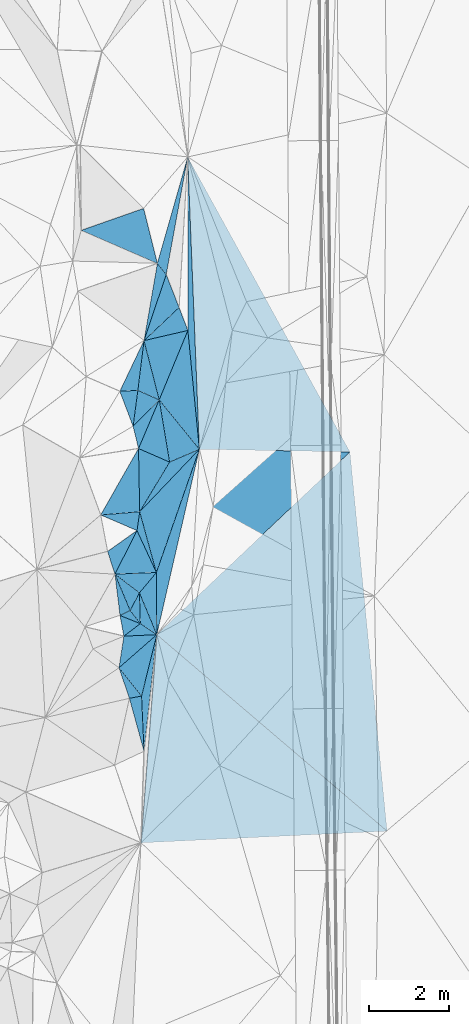
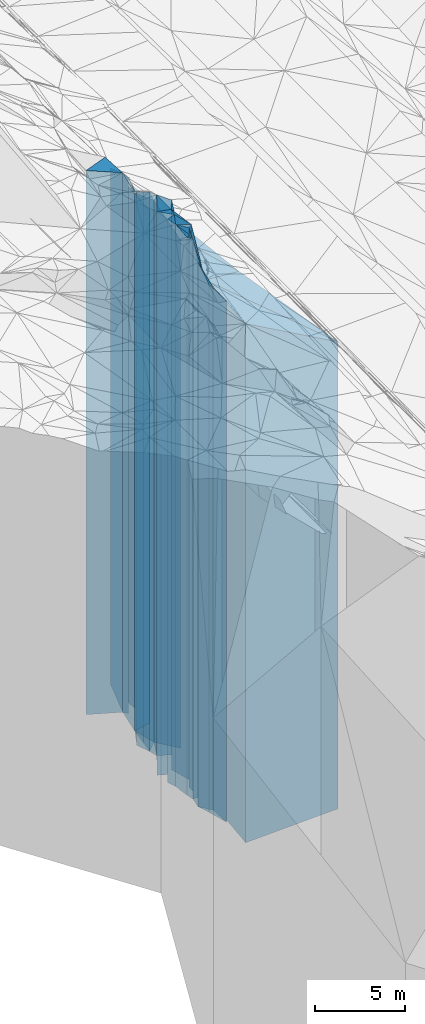
# One storey, part 200 of 275: 42 plates.
"""IFC2X3 building model written with IfcOpenShell, lengths in millimetres."""

from ifc_helpers import new_model, si_unit, frame, origin_with_axes, place, context, subcontext, project, spatial, faceted_brep, material, type_object, element, save


model = new_model("IFC2X3")

# Units and contexts
model_context = context("Model", 3, precision=1e-05, world=origin_with_axes())
body_context = subcontext(model_context, "Body", "Model", "MODEL_VIEW")
ifc_project = project(units=[si_unit("LENGTHUNIT", "METRE", prefix="MILLI"), si_unit("AREAUNIT", "SQUARE_METRE"), si_unit("VOLUMEUNIT", "CUBIC_METRE"), si_unit("MASSUNIT", "GRAM", prefix="KILO"), si_unit("TIMEUNIT", "SECOND"), si_unit("PLANEANGLEUNIT", "RADIAN"), si_unit("SOLIDANGLEUNIT", "STERADIAN"), si_unit("THERMODYNAMICTEMPERATUREUNIT", "DEGREE_CELSIUS"), si_unit("LUMINOUSINTENSITYUNIT", "LUMEN")], contexts=[model_context])

# Site, building, storey
site_placement = place(None, origin_with_axes())
site = spatial("IfcSite", under=ifc_project, at=site_placement, CompositionType="ELEMENT")
building_placement = place(site_placement, origin_with_axes())
building = spatial("IfcBuilding", under=site, at=building_placement, Name="Undefined", CompositionType="ELEMENT")
storey_placement = place(building_placement, origin_with_axes())
storey = spatial("IfcBuildingStorey", under=building, at=storey_placement, Name="Undefined", CompositionType="ELEMENT", Elevation=0.0)

# Plates
ifc_material = material()
plate_type_1 = type_object("IfcPlateType", PredefinedType="NOTDEFINED")
plate_1_placement = place(storey_placement, frame((-97470.1992591379, 36582.1176722173, 23411.5), z_axis=(0.999205181096027, 0.0398623390038303, 0.0), x_axis=(0.0398623390038315, -0.999205181096027, 0.0)))
element("IfcPlate", 1, at=plate_1_placement, inside=storey, type_object=plate_type_1, material=ifc_material, Name="00", context=body_context, shape_type="Brep", body=[
    faceted_brep([(0.0, -19574.5109863281, 0.0), (7486.21093749999, -15583.5, 3739.80737304688), (7486.21093749999, 15583.5, 3739.80737304688), (0.0, 15583.5, 0.0), (7271.146484375, -19012.5109863281, -8.73114913702011e-09), (7271.146484375, 15583.5, -8.73114913702011e-09)], [[[0, 1, 2, 3]], [[1, 4, 5, 2]], [[4, 0, 3, 5]], [[5, 3, 2]], [[4, 1, 0]]]),
])
plate_type_2 = type_object("IfcPlateType", PredefinedType="NOTDEFINED")
plate_2_placement = place(storey_placement, frame((-98238.1983915718, 24706.1417825239, 23411.5), z_axis=(0.649050026928947, 0.760745727916715, 0.0), x_axis=(0.760745727916717, -0.649050026928945, 0.0)))
element("IfcPlate", 2, at=plate_2_placement, inside=storey, type_object=plate_type_2, material=ifc_material, Name="00", context=body_context, shape_type="Brep", body=[
    faceted_brep([(0.0, -19434.5109863281, 0.0), (704.255493164048, -15583.5, 6574.982421875), (704.255493164048, 15583.5, 6574.982421875), (0.0, 15583.5, 0.0), (7528.404296875, -16175.5109863281, -2.89292074739933e-08), (7528.404296875, 15583.5, -2.89292074739933e-08)], [[[0, 1, 2, 3]], [[1, 4, 5, 2]], [[4, 0, 3, 5]], [[5, 3, 2]], [[4, 1, 0]]]),
])
plate_type_3 = type_object("IfcPlateType", PredefinedType="NOTDEFINED")
plate_3_placement = place(storey_placement, frame((-98238.1983915718, 24706.1417825239, 23707.5), z_axis=(0.997106036471852, -0.076023365035977, 0.0), x_axis=(-0.0760233650359758, -0.997106036471852, 0.0)))
element("IfcPlate", 3, at=plate_3_placement, inside=storey, type_object=plate_type_3, material=ifc_material, Name="00", context=body_context, shape_type="Brep", body=[
    faceted_brep([(3.63797880709171e-12, -19138.5, 0.0), (4436.76904296874, -15879.5, 6082.1005859375), (4436.76904296874, 15879.5, 6082.1005859375), (3.63797880709171e-12, 15879.5, 0.0), (5192.95703125, -19442.5, 8.73114913702011e-09), (5192.95703125, 15879.5, 8.73114913702011e-09)], [[[0, 1, 2, 3]], [[1, 4, 5, 2]], [[4, 0, 3, 5]], [[5, 3, 2]], [[4, 1, 0]]]),
])
plate_type_4 = type_object("IfcPlateType", PredefinedType="NOTDEFINED")
plate_4_placement = place(storey_placement, frame((-98648.2817788003, 24980.7626402883, 25337.0), z_axis=(0.606668938331786, -0.794954589434757, 0.0), x_axis=(-0.794954589434757, -0.606668938331787, 0.0)))
element("IfcPlate", 4, at=plate_4_placement, inside=storey, type_object=plate_type_4, material=ifc_material, Name="00", context=body_context, shape_type="Brep", body=[
    faceted_brep([(-7.27595761418343e-12, -19333.0, -1.45519152283669e-11), (-159.393722534194, -17509.0, 467.095977783189), (-159.393722534194, 17509.0, 467.095977783189), (-7.27595761418343e-12, 17509.0, -1.45519152283669e-11), (514.198425292969, -20573.0, -8.14907252788544e-10), (514.198425292969, 17509.0, -8.14907252788544e-10)], [[[0, 1, 2, 3]], [[1, 4, 5, 2]], [[4, 0, 3, 5]], [[5, 3, 2]], [[4, 1, 0]]]),
])
plate_type_5 = type_object("IfcPlateType", PredefinedType="NOTDEFINED")
plate_5_placement = place(storey_placement, frame((-98670.1738100079, 25747.3921068297, 26249.0), z_axis=(0.885665246512403, -0.464324316744369, 0.0), x_axis=(-0.464324316744365, -0.885665246512405, 0.0)))
element("IfcPlate", 5, at=plate_5_placement, inside=storey, type_object=plate_type_5, material=ifc_material, Name="00", context=body_context, shape_type="Brep", body=[
    faceted_brep([(0.0, -19661.0, 1.45519152283669e-11), (668.812072753906, -18421.0, 375.353729248047), (668.812072753906, 18421.0, 375.353729248047), (0.0, 18421.0, 1.45519152283669e-11), (498.196746826179, -19541.0, -5.67524693906307e-10), (498.196746826179, 18421.0, -5.67524693906307e-10)], [[[0, 1, 2, 3]], [[1, 4, 5, 2]], [[4, 0, 3, 5]], [[5, 3, 2]], [[4, 1, 0]]]),
])
plate_type_6 = type_object("IfcPlateType", PredefinedType="NOTDEFINED")
plate_6_placement = place(storey_placement, frame((-98648.2817788003, 24980.7626402883, 26249.0), z_axis=(-0.789196179336092, -0.614141181261536, 0.0), x_axis=(-0.614141181261532, 0.789196179336096, 0.0)))
element("IfcPlate", 6, at=plate_6_placement, inside=storey, type_object=plate_type_6, material=ifc_material, Name="00", context=body_context, shape_type="Brep", body=[
    faceted_brep([(2.91038304567337e-11, -18421.0, 1.45519152283669e-11), (470.519104003935, -19541.0, 274.065246582039), (470.519104003935, 18421.0, 274.065246582039), (0.0, 18421.0, 1.45519152283669e-11), (412.310577392607, -19541.0, 5.67524693906307e-10), (412.310577392607, 18421.0, 5.67524693906307e-10)], [[[0, 1, 2, 3]], [[1, 4, 5, 2]], [[4, 0, 3, 5]], [[5, 3, 2]], [[4, 1, 0]]]),
])
plate_type_7 = type_object("IfcPlateType", PredefinedType="NOTDEFINED")
plate_7_placement = place(storey_placement, frame((-99153.538195565, 25183.779765965, 26809.0), z_axis=(-0.436781510934569, 0.899567624865255, 0.0), x_axis=(0.899567624865254, 0.436781510934571, 0.0)))
element("IfcPlate", 7, at=plate_7_placement, inside=storey, type_object=plate_type_7, material=ifc_material, Name="00", context=body_context, shape_type="Brep", body=[
    faceted_brep([(0.0, -18981.0, 0.0), (335.143463134751, -19271.0, 978.661743164063), (335.143463134751, 18981.0, 978.661743164063), (0.0, 18981.0, 0.0), (280.178527832017, -18981.0, -2.00816430151463e-09), (280.178527832017, 18981.0, -2.00816430151463e-09)], [[[0, 1, 2, 3]], [[1, 4, 5, 2]], [[4, 0, 3, 5]], [[5, 3, 2]], [[4, 1, 0]]]),
])
plate_type_8 = type_object("IfcPlateType", PredefinedType="NOTDEFINED")
plate_8_placement = place(storey_placement, frame((-99057.0461609876, 24668.8144396924, 25337.0), z_axis=(0.988124865303162, -0.153653020047142, 0.0), x_axis=(-0.153653020047141, -0.988124865303162, 0.0)))
element("IfcPlate", 8, at=plate_8_placement, inside=storey, type_object=plate_type_8, material=ifc_material, Name="00", context=body_context, shape_type="Brep", body=[
    faceted_brep([(0.0, -20573.0, -1.45519152283669e-11), (-162.702514648436, -17509.0, 803.388366699219), (-162.702514648436, 17509.0, 803.388366699219), (-7.27595761418343e-12, 17509.0, -1.45519152283669e-11), (796.115539550783, -19533.0, 5.0931703299284e-10), (796.115539550783, 17509.0, 5.0931703299284e-10)], [[[0, 1, 2, 3]], [[1, 4, 5, 2]], [[4, 0, 3, 5]], [[5, 3, 2]], [[4, 1, 0]]]),
])
plate_type_9 = type_object("IfcPlateType", PredefinedType="NOTDEFINED")
plate_9_placement = place(storey_placement, frame((-99179.3717224447, 23882.1528497986, 25619.0), z_axis=(0.946352695047988, 0.323135539016386, 0.0), x_axis=(0.323135539016389, -0.946352695047987, 0.0)))
element("IfcPlate", 9, at=plate_9_placement, inside=storey, type_object=plate_type_9, material=ifc_material, Name="00", context=body_context, shape_type="Brep", body=[
    faceted_brep([(0.0, -19251.0, 1.45519152283669e-11), (846.64013671875, -17791.0, 304.959808349609), (846.64013671875, 17791.0, 304.959808349609), (0.0, 17791.0, 1.45519152283669e-11), (803.056640625, -18111.0, 0.0), (803.056640625, 17791.0, 0.0)], [[[0, 1, 2, 3]], [[1, 4, 5, 2]], [[4, 0, 3, 5]], [[5, 3, 2]], [[4, 1, 0]]]),
])
plate_type_10 = type_object("IfcPlateType", PredefinedType="NOTDEFINED")
plate_10_placement = place(storey_placement, frame((-98617.1926753688, 23179.4760257686, 25549.0), z_axis=(0.185997213942061, -0.982550271693918, 0.0), x_axis=(-0.982550271693919, -0.185997213942052, 0.0)))
element("IfcPlate", 10, at=plate_10_placement, inside=storey, type_object=plate_type_10, material=ifc_material, Name="00", context=body_context, shape_type="Brep", body=[
    faceted_brep([(1.45519152283669e-11, -17861.0, 0.0), (196.066696167021, -17721.0, 1360.13159179688), (196.066696167021, 17721.0, 1360.13159179688), (1.45519152283669e-11, 17721.0, 0.0), (308.058441162109, -18181.0, 1.65891833603382e-09), (308.058441162109, 17721.0, 1.65891833603382e-09)], [[[0, 1, 2, 3]], [[1, 4, 5, 2]], [[4, 0, 3, 5]], [[5, 3, 2]], [[4, 1, 0]]]),
])
plate_type_11 = type_object("IfcPlateType", PredefinedType="NOTDEFINED")
plate_11_placement = place(storey_placement, frame((-98617.1926753688, 23179.4760257686, 25337.0), z_axis=(0.999035664107292, 0.0439060570047157, 0.0), x_axis=(0.0439060570047185, -0.999035664107292, 0.0)))
element("IfcPlate", 11, at=plate_11_placement, inside=storey, type_object=plate_type_11, material=ifc_material, Name="00", context=body_context, shape_type="Brep", body=[
    faceted_brep([(0.0, -18073.0, 0.0), (-1508.55334472657, -17509.0, 445.658691406235), (-1508.55334472657, 17509.0, 445.658691406235), (-7.27595761418343e-12, 17509.0, -1.45519152283669e-11), (1374.19067382813, -17933.0, -1.04773789644241e-09), (1374.19067382813, 17509.0, -1.04773789644241e-09)], [[[0, 1, 2, 3]], [[1, 4, 5, 2]], [[4, 0, 3, 5]], [[5, 3, 2]], [[4, 1, 0]]]),
])
plate_type_12 = type_object("IfcPlateType", PredefinedType="NOTDEFINED")
plate_12_placement = place(storey_placement, frame((-99153.538195565, 25183.779765965, 26249.0), z_axis=(0.982894293571423, 0.184170593919695, 0.0), x_axis=(0.184170593919694, -0.982894293571423, 0.0)))
element("IfcPlate", 12, at=plate_12_placement, inside=storey, type_object=plate_type_12, material=ifc_material, Name="00", context=body_context, shape_type="Brep", body=[
    faceted_brep([(-7.27595761418343e-12, -19541.0, 0.0), (292.597747802727, -18421.0, 459.22387695311), (292.597747802727, 18421.0, 459.22387695311), (0.0, 18421.0, 1.45519152283669e-11), (523.927490234368, -19661.0, 1.45519152283669e-10), (523.927490234368, 18421.0, 1.45519152283669e-10)], [[[0, 1, 2, 3]], [[1, 4, 5, 2]], [[4, 0, 3, 5]], [[5, 3, 2]], [[4, 1, 0]]]),
])
plate_type_13 = type_object("IfcPlateType", PredefinedType="NOTDEFINED")
plate_13_placement = place(storey_placement, frame((-98617.1926753688, 23179.4760257686, 25337.0), z_axis=(-0.970540890617657, 0.240936463905083, 0.0), x_axis=(0.240936463905086, 0.970540890617656, 0.0)))
element("IfcPlate", 13, at=plate_13_placement, inside=storey, type_object=plate_type_13, material=ifc_material, Name="00", context=body_context, shape_type="Brep", body=[
    faceted_brep([(0.0, -18073.0, 0.0), (546.527160644531, -19533.0, 714.918212890625), (546.527160644531, 17509.0, 714.918212890625), (-7.27595761418343e-12, 17509.0, -1.45519152283669e-11), (1573.00512695313, -17509.0, -1.17870513349772e-09), (1573.00512695313, 17509.0, -1.17870513349772e-09)], [[[0, 1, 2, 3]], [[1, 4, 5, 2]], [[4, 0, 3, 5]], [[5, 3, 2]], [[4, 1, 0]]]),
])
plate_type_14 = type_object("IfcPlateType", PredefinedType="NOTDEFINED")
plate_14_placement = place(storey_placement, frame((-98566.6692560539, 35305.6810126596, 26179.0), z_axis=(0.330860922101641, -0.94367952728988, 0.0), x_axis=(-0.943679527289882, -0.330860922101635, 0.0)))
element("IfcPlate", 14, at=plate_14_placement, inside=storey, type_object=plate_type_14, material=ifc_material, Name="00", context=body_context, shape_type="Brep", body=[
    faceted_brep([(0.0, -18711.0, -1.45519152283669e-11), (129.411132812515, -18351.0, 1404.61840820311), (129.411132812515, 18351.0, 1404.61840820311), (0.0, 18351.0, -1.45519152283669e-11), (1645.14440917969, -18671.0, 7.15954229235649e-09), (1645.14440917969, 18351.0, 7.15954229235649e-09)], [[[0, 1, 2, 3]], [[1, 4, 5, 2]], [[4, 0, 3, 5]], [[5, 3, 2]], [[4, 1, 0]]]),
])
plate_type_15 = type_object("IfcPlateType", PredefinedType="NOTDEFINED")
plate_15_placement = place(storey_placement, frame((-98556.6871840692, 32018.9804850425, 26044.0), z_axis=(-0.947902138619609, 0.318561666872164, 0.0), x_axis=(0.318561666872161, 0.94790213861961, 0.0)))
element("IfcPlate", 15, at=plate_15_placement, inside=storey, type_object=plate_type_15, material=ifc_material, Name="00", context=body_context, shape_type="Brep", body=[
    faceted_brep([(1.45519152283669e-11, -18396.0, -1.45519152283669e-11), (1924.39343261719, -18486.0, 295.820983886719), (1924.39343261719, 18216.0, 295.820983886719), (2.91038304567337e-11, 18216.0, -2.91038304567337e-11), (1734.15686035156, -18216.0, 5.80621417611837e-09), (1734.15686035156, 18216.0, 5.80621417611837e-09)], [[[0, 1, 2, 3]], [[1, 4, 5, 2]], [[4, 0, 3, 5]], [[5, 3, 2]], [[4, 1, 0]]]),
])
plate_type_16 = type_object("IfcPlateType", PredefinedType="NOTDEFINED")
plate_16_placement = place(storey_placement, frame((-98224.058566093, 33937.3543283022, 25407.0), z_axis=(0.780651010687268, 0.62496719874962, 0.0), x_axis=(0.624967198749629, -0.780651010687261, 0.0)))
element("IfcPlate", 16, at=plate_16_placement, inside=storey, type_object=plate_type_16, material=ifc_material, Name="00", context=body_context, shape_type="Brep", body=[
    faceted_brep([(-1.45519152283669e-11, -19123.0, 0.0), (-1593.49987792969, -17579.0, 2241.39135742188), (-1593.49987792969, 17579.0, 2241.39135742188), (1.45519152283669e-11, 17579.0, 0.0), (351.710113525376, -18853.0, -4.65661287307739e-10), (351.710113525376, 17579.0, -4.65661287307739e-10)], [[[0, 1, 2, 3]], [[1, 4, 5, 2]], [[4, 0, 3, 5]], [[5, 3, 2]], [[4, 1, 0]]]),
])
plate_type_17 = type_object("IfcPlateType", PredefinedType="NOTDEFINED")
plate_17_placement = place(storey_placement, frame((-98556.6871840692, 32018.9804850425, 25349.0), z_axis=(-0.686407018989633, 0.72721757698901, 0.0), x_axis=(0.727217576989016, 0.686407018989626, 0.0)))
element("IfcPlate", 17, at=plate_17_placement, inside=storey, type_object=plate_type_17, material=ifc_material, Name="00", context=body_context, shape_type="Brep", body=[
    faceted_brep([(-1.45519152283669e-11, -19091.0, 0.0), (1530.064453125, -18911.0, 816.212341308594), (1530.064453125, 17521.0, 816.212341308594), (0.0, 17521.0, 1.45519152283669e-11), (1198.70764160155, -17521.0, 5.95173332840204e-09), (1198.70764160155, 17521.0, 5.95173332840204e-09)], [[[0, 1, 2, 3]], [[1, 4, 5, 2]], [[4, 0, 3, 5]], [[5, 3, 2]], [[4, 1, 0]]]),
])
plate_type_18 = type_object("IfcPlateType", PredefinedType="NOTDEFINED")
plate_18_placement = place(storey_placement, frame((-98556.6871840692, 32018.9804850425, 25274.0), z_axis=(-0.22571742799448, 0.974192815976158, 0.0), x_axis=(0.974192815976159, 0.225717427994477, 0.0)))
element("IfcPlate", 18, at=plate_18_placement, inside=storey, type_object=plate_type_18, material=ifc_material, Name="00", context=body_context, shape_type="Brep", body=[
    faceted_brep([(0.0, -19166.0, -1.81898940354586e-12), (1034.94519042967, -17596.0, 604.804443359382), (1034.94519042967, 17446.0, 604.804443359382), (-1.45519152283669e-11, 17446.0, 7.27595761418343e-12), (1119.86608886719, -17446.0, -2.46654963120818e-09), (1119.86608886719, 17446.0, -2.46654963120818e-09)], [[[0, 1, 2, 3]], [[1, 4, 5, 2]], [[4, 0, 3, 5]], [[5, 3, 2]], [[4, 1, 0]]]),
])
plate_type_19 = type_object("IfcPlateType", PredefinedType="NOTDEFINED")
plate_19_placement = place(storey_placement, frame((-98178.7387428365, 30546.0056122867, 25126.0), z_axis=(0.776233136003161, 0.630445968002571, 0.0), x_axis=(0.630445968002567, -0.776233136003164, 0.0)))
element("IfcPlate", 19, at=plate_19_placement, inside=storey, type_object=plate_type_19, material=ifc_material, Name="00", context=body_context, shape_type="Brep", body=[
    faceted_brep([(0.0, -19604.0, 0.0), (-890.06420898436, -17594.0, 1641.45837402345), (-890.06420898436, 17298.0, 1641.45837402345), (0.0, 17298.0, 0.0), (1583.61608886719, -17298.0, 4.32919478043914e-09), (1583.61608886719, 17298.0, 4.32919478043914e-09)], [[[0, 1, 2, 3]], [[1, 4, 5, 2]], [[4, 0, 3, 5]], [[5, 3, 2]], [[4, 1, 0]]]),
])
plate_type_20 = type_object("IfcPlateType", PredefinedType="NOTDEFINED")
plate_20_placement = place(storey_placement, frame((-97465.7217101164, 32271.7537720861, 25126.0), z_axis=(0.995369393588138, 0.0961237239602277, 0.0), x_axis=(0.0961237239602239, -0.995369393588139, 0.0)))
element("IfcPlate", 20, at=plate_20_placement, inside=storey, type_object=plate_type_20, material=ifc_material, Name="00", context=body_context, shape_type="Brep", body=[
    faceted_brep([(7.27595761418343e-12, -17594.0, 0.0), (-4290.83447265624, -17860.0, 409.871429443359), (-4290.83447265624, 17298.0, 409.871429443359), (0.0, 17298.0, 0.0), (2968.75048828125, -17298.0, -3.08500602841377e-09), (2968.75048828125, 17298.0, -3.08500602841377e-09)], [[[0, 1, 2, 3]], [[1, 4, 5, 2]], [[4, 0, 3, 5]], [[5, 3, 2]], [[4, 1, 0]]]),
])
plate_type_21 = type_object("IfcPlateType", PredefinedType="NOTDEFINED")
plate_21_placement = place(storey_placement, frame((-99158.1454780888, 30758.0491147629, 26134.0), z_axis=(-0.0523157720188817, 0.998630592360393, 0.0), x_axis=(0.998630592360393, 0.0523157720188781, 0.0)))
element("IfcPlate", 21, at=plate_21_placement, inside=storey, type_object=plate_type_21, material=ifc_material, Name="00", context=body_context, shape_type="Brep", body=[
    faceted_brep([(-3.63797880709171e-12, -19356.0, 0.0), (666.601257324219, -18306.0, 1227.73889160157), (666.601257324219, 18306.0, 1227.73889160157), (0.0, 18306.0, 0.0), (449.44409179686, -19176.0, -3.20142135024071e-10), (449.44409179686, 18306.0, -3.20142135024071e-10)], [[[0, 1, 2, 3]], [[1, 4, 5, 2]], [[4, 0, 3, 5]], [[5, 3, 2]], [[4, 1, 0]]]),
])
plate_type_22 = type_object("IfcPlateType", PredefinedType="NOTDEFINED")
plate_22_placement = place(storey_placement, frame((-98827.7861381995, 29887.2663022615, 26279.0), z_axis=(-0.712327538669236, 0.701847189674097, 0.0), x_axis=(0.701847189674096, 0.712327538669237, 0.0)))
element("IfcPlate", 22, at=plate_22_placement, inside=storey, type_object=plate_type_22, material=ifc_material, Name="00", context=body_context, shape_type="Brep", body=[
    faceted_brep([(0.0, -19611.0, 1.45519152283669e-11), (720.178894042947, -19031.0, 543.270080566406), (720.178894042947, 18451.0, 543.270080566406), (-1.45519152283669e-11, 18451.0, 0.0), (924.770263671875, -18451.0, 2.2409949451685e-09), (924.770263671875, 18451.0, 2.2409949451685e-09)], [[[0, 1, 2, 3]], [[1, 4, 5, 2]], [[4, 0, 3, 5]], [[5, 3, 2]], [[4, 1, 0]]]),
])
plate_type_23 = type_object("IfcPlateType", PredefinedType="NOTDEFINED")
plate_23_placement = place(storey_placement, frame((-97920.7441179216, 28998.1235839929, 25126.0), z_axis=(-0.395299046040721, 0.918552483094622, 0.0), x_axis=(0.918552483094622, 0.395299046040721, 0.0)))
element("IfcPlate", 23, at=plate_23_placement, inside=storey, type_object=plate_type_23, material=ifc_material, Name="00", context=body_context, shape_type="Brep", body=[
    faceted_brep([(0.0, -20444.0, 0.0), (374.894683837891, -19604.0, 1523.7958984375), (374.894683837891, 17298.0, 1523.7958984375), (0.0, 17298.0, 0.0), (806.039672851577, -17298.0, 1.09139364212751e-09), (806.039672851577, 17298.0, 1.09139364212751e-09)], [[[0, 1, 2, 3]], [[1, 4, 5, 2]], [[4, 0, 3, 5]], [[5, 3, 2]], [[4, 1, 0]]]),
])
plate_type_24 = type_object("IfcPlateType", PredefinedType="NOTDEFINED")
plate_24_placement = place(storey_placement, frame((-98709.3168491968, 30781.5621300295, 26569.0), z_axis=(0.0523157720188817, -0.998630592360393, 0.0), x_axis=(-0.998630592360392, -0.0523157720188845, 0.0)))
element("IfcPlate", 24, at=plate_24_placement, inside=storey, type_object=plate_type_24, material=ifc_material, Name="00", context=body_context, shape_type="Brep", body=[
    faceted_brep([(0.0, -18741.0, -1.45519152283669e-11), (165.092834472656, -19321.0, 886.873352050781), (165.092834472656, 18741.0, 886.873352050781), (0.0, 18741.0, -1.45519152283669e-11), (449.44409179686, -18921.0, -3.20142135024071e-10), (449.44409179686, 18741.0, -3.20142135024071e-10)], [[[0, 1, 2, 3]], [[1, 4, 5, 2]], [[4, 0, 3, 5]], [[5, 3, 2]], [[4, 1, 0]]]),
])
plate_type_25 = type_object("IfcPlateType", PredefinedType="NOTDEFINED")
plate_25_placement = place(storey_placement, frame((-98556.6871840692, 32018.9804850425, 26134.0), z_axis=(0.992478689979371, -0.122417522997455, 0.0), x_axis=(-0.122417522997458, -0.99247868997937, 0.0)))
element("IfcPlate", 25, at=plate_25_placement, inside=storey, type_object=plate_type_25, material=ifc_material, Name="00", context=body_context, shape_type="Brep", body=[
    faceted_brep([(1.45519152283669e-11, -18306.0, -1.45519152283669e-11), (1415.62866210938, -18596.0, 555.423706054688), (1415.62866210938, 18306.0, 555.423706054688), (0.0, 18306.0, 0.0), (1246.7958984375, -19176.0, -4.51109372079372e-10), (1246.7958984375, 18306.0, -4.51109372079372e-10)], [[[0, 1, 2, 3]], [[1, 4, 5, 2]], [[4, 0, 3, 5]], [[5, 3, 2]], [[4, 1, 0]]]),
])
plate_type_26 = type_object("IfcPlateType", PredefinedType="NOTDEFINED")
plate_26_placement = place(storey_placement, frame((-98692.7826126044, 29334.6597079497, 26279.0), z_axis=(0.399591930077884, 0.916693127178682, 0.0), x_axis=(0.916693127178681, -0.399591930077887, 0.0)))
element("IfcPlate", 26, at=plate_26_placement, inside=storey, type_object=plate_type_26, material=ifc_material, Name="00", context=body_context, shape_type="Brep", body=[
    faceted_brep([(-9.09494701772928e-13, -19711.0, -1.45519152283669e-11), (-12.823564529448, -18451.0, 1315.84020996092), (-12.823564529448, 18451.0, 1315.84020996092), (-1.45519152283669e-11, 18451.0, 0.0), (842.199523925752, -19291.0, -1.30967237055302e-09), (842.199523925752, 18451.0, -1.30967237055302e-09)], [[[0, 1, 2, 3]], [[1, 4, 5, 2]], [[4, 0, 3, 5]], [[5, 3, 2]], [[4, 1, 0]]]),
])
plate_type_27 = type_object("IfcPlateType", PredefinedType="NOTDEFINED")
plate_27_placement = place(storey_placement, frame((-99635.1281454736, 27682.4536382715, 26889.0), z_axis=(-0.081491319040368, 0.996674051493798, 0.0), x_axis=(0.996674051493797, 0.0814913190403743, 0.0)))
element("IfcPlate", 27, at=plate_27_placement, inside=storey, type_object=plate_type_27, material=ifc_material, Name="00", context=body_context, shape_type="Brep", body=[
    faceted_brep([(0.0, -19291.0, 0.0), (1073.85180664061, -19101.0, 1569.91796875), (1073.85180664061, 19061.0, 1569.91796875), (-1.45519152283669e-11, 19061.0, 0.0), (974.063659667969, -19061.0, 5.1804818212986e-09), (974.063659667969, 19061.0, 5.1804818212986e-09)], [[[0, 1, 2, 3]], [[1, 4, 5, 2]], [[4, 0, 3, 5]], [[5, 3, 2]], [[4, 1, 0]]]),
])
plate_type_28 = type_object("IfcPlateType", PredefinedType="NOTDEFINED")
plate_28_placement = place(storey_placement, frame((-97920.7441179216, 28998.1235839929, 25126.0), z_axis=(0.856946662857383, -0.515405099914227, 0.0), x_axis=(-0.515405099914227, -0.856946662857384, 0.0)))
element("IfcPlate", 28, at=plate_28_placement, inside=storey, type_object=plate_type_28, material=ifc_material, Name="00", context=body_context, shape_type="Brep", body=[
    faceted_brep([(0.0, -20444.0, 0.0), (-654.646789550774, -17298.0, 470.252716064439), (-654.646789550774, 17298.0, 470.252716064439), (0.0, 17298.0, 0.0), (1442.67114257813, -20824.0, 4.72937244921923e-09), (1442.67114257813, 17298.0, 4.72937244921923e-09)], [[[0, 1, 2, 3]], [[1, 4, 5, 2]], [[4, 0, 3, 5]], [[5, 3, 2]], [[4, 1, 0]]]),
])
plate_type_29 = type_object("IfcPlateType", PredefinedType="NOTDEFINED")
plate_29_placement = place(storey_placement, frame((-98178.7387428365, 30546.0056122867, 26279.0), z_axis=(0.712327538669236, -0.701847189674097, 0.0), x_axis=(-0.701847189674103, -0.712327538669231, 0.0)))
element("IfcPlate", 29, at=plate_29_placement, inside=storey, type_object=plate_type_29, material=ifc_material, Name="00", context=body_context, shape_type="Brep", body=[
    faceted_brep([(0.0, -18451.0, 0.0), (1223.65527343751, -19711.0, 484.012115478516), (1223.65527343751, 18451.0, 484.012115478516), (-1.45519152283669e-11, 18451.0, 0.0), (924.770263671882, -19611.0, 2.21189111471176e-09), (924.770263671875, 18451.0, 2.2409949451685e-09)], [[[0, 1, 2, 3]], [[1, 4, 5, 2]], [[4, 0, 3, 5]], [[5, 3, 2]], [[4, 1, 0]]]),
])
plate_type_30 = type_object("IfcPlateType", PredefinedType="NOTDEFINED")
plate_30_placement = place(storey_placement, frame((-98664.3041781086, 27761.8313706005, 26864.0), z_axis=(0.0814913190403677, -0.996674051493798, 0.0), x_axis=(-0.996674051493797, -0.081491319040373, 0.0)))
element("IfcPlate", 30, at=plate_30_placement, inside=storey, type_object=plate_type_30, material=ifc_material, Name="00", context=body_context, shape_type="Brep", body=[
    faceted_brep([(1.45519152283669e-11, -19086.0, -7.27595761418343e-12), (104.715950012222, -19036.0, 459.928863525391), (104.715950012222, 19036.0, 459.928863525391), (7.27595761418343e-12, 19036.0, 1.45519152283669e-11), (974.063659667998, -19316.0, 5.1804818212986e-09), (974.063659667998, 19036.0, 5.1804818212986e-09)], [[[0, 1, 2, 3]], [[1, 4, 5, 2]], [[4, 0, 3, 5]], [[5, 3, 2]], [[4, 1, 0]]]),
])
plate_type_31 = type_object("IfcPlateType", PredefinedType="NOTDEFINED")
plate_31_placement = place(storey_placement, frame((-98664.3041781086, 27761.8313706005, 26699.0), z_axis=(-0.856946662857383, 0.515405099914227, 0.0), x_axis=(0.515405099914228, 0.856946662857383, 0.0)))
element("IfcPlate", 31, at=plate_31_placement, inside=storey, type_object=plate_type_31, material=ifc_material, Name="00", context=body_context, shape_type="Brep", body=[
    faceted_brep([(0.0, -19251.0, 1.45519152283669e-11), (1333.15209960936, -19291.0, 835.048217773438), (1333.15209960936, 18871.0, 835.048217773438), (-7.27595761418343e-12, 18871.0, 0.0), (1442.67114257811, -18871.0, 4.72937244921923e-09), (1442.67114257811, 18871.0, 4.72937244921923e-09)], [[[0, 1, 2, 3]], [[1, 4, 5, 2]], [[4, 0, 3, 5]], [[5, 3, 2]], [[4, 1, 0]]]),
])
plate_type_32 = type_object("IfcPlateType", PredefinedType="NOTDEFINED")
plate_32_placement = place(storey_placement, frame((-99279.5153443607, 26210.5366787644, 26759.0), z_axis=(-0.0393991519990168, 0.999223551975111, 0.0), x_axis=(0.999223551975112, 0.0393991519990183, 0.0)))
element("IfcPlate", 32, at=plate_32_placement, inside=storey, type_object=plate_type_32, material=ifc_material, Name="00", context=body_context, shape_type="Brep", body=[
    faceted_brep([(0.0, -19321.0, 0.0), (590.620910644517, -19141.0, 1061.91662597657), (590.620910644517, 18931.0, 1061.91662597657), (0.0, 18931.0, 7.27595761418343e-12), (1032.47277832031, -18931.0, -8.58562998473644e-10), (1032.47277832031, 18931.0, -8.58562998473644e-10)], [[[0, 1, 2, 3]], [[1, 4, 5, 2]], [[4, 0, 3, 5]], [[5, 3, 2]], [[4, 1, 0]]]),
])
plate_type_33 = type_object("IfcPlateType", PredefinedType="NOTDEFINED")
plate_33_placement = place(storey_placement, frame((-98664.3041781086, 27761.8313706005, 26759.0), z_axis=(0.989895166211723, -0.141801128030297, 0.0), x_axis=(-0.141801128030334, -0.989895166211718, 0.0)))
element("IfcPlate", 33, at=plate_33_placement, inside=storey, type_object=plate_type_33, material=ifc_material, Name="00", context=body_context, shape_type="Brep", body=[
    faceted_brep([(0.0, -19191.0, 0.0), (1436.29711914062, -18931.0, 626.45874023436), (1436.29711914062, 18931.0, 626.45874023436), (0.0, 18931.0, 7.27595761418343e-12), (471.699066162108, -19141.0, -1.16415321826935e-09), (471.699066162108, 18931.0, -1.16415321826935e-09)], [[[0, 1, 2, 3]], [[1, 4, 5, 2]], [[4, 0, 3, 5]], [[5, 3, 2]], [[4, 1, 0]]]),
])
plate_type_34 = type_object("IfcPlateType", PredefinedType="NOTDEFINED")
plate_34_placement = place(storey_placement, frame((-99279.5153443607, 26210.5366787644, 26759.0), z_axis=(0.605120539842066, 0.796133865792208, 0.0), x_axis=(0.796133865792211, -0.605120539842063, 0.0)))
element("IfcPlate", 34, at=plate_34_placement, inside=storey, type_object=plate_type_34, material=ifc_material, Name="00", context=body_context, shape_type="Brep", body=[
    faceted_brep([(0.0, -19321.0, 0.0), (796.732849121079, -18931.0, 656.670959472656), (796.732849121079, 18931.0, 656.670959472656), (0.0, 18931.0, 7.27595761418343e-12), (765.375732421875, -19151.0, 4.72209649160504e-09), (765.375732421875, 18931.0, 4.72209649160504e-09)], [[[0, 1, 2, 3]], [[1, 4, 5, 2]], [[4, 0, 3, 5]], [[5, 3, 2]], [[4, 1, 0]]]),
])
plate_type_35 = type_object("IfcPlateType", PredefinedType="NOTDEFINED")
plate_35_placement = place(storey_placement, frame((-98247.8442458582, 26251.2152298056, 25337.0), z_axis=(0.766365091778651, -0.642405281814448, 0.0), x_axis=(-0.642405281814456, -0.766365091778644, 0.0)))
element("IfcPlate", 35, at=plate_35_placement, inside=storey, type_object=plate_type_35, material=ifc_material, Name="00", context=body_context, shape_type="Brep", body=[
    faceted_brep([(1.45519152283669e-11, -20353.0, 0.0), (1177.89379882814, -17509.0, 999.95556640625), (1177.89379882814, 17509.0, 999.95556640625), (-7.27595761418343e-12, 17509.0, -1.45519152283669e-11), (657.41918945314, -20573.0, 1.13504938781261e-09), (657.41918945314, 17509.0, 1.13504938781261e-09)], [[[0, 1, 2, 3]], [[1, 4, 5, 2]], [[4, 0, 3, 5]], [[5, 3, 2]], [[4, 1, 0]]]),
])
plate_type_36 = type_object("IfcPlateType", PredefinedType="NOTDEFINED")
plate_36_placement = place(storey_placement, frame((-98901.498674756, 25306.1565609483, 26809.0), z_axis=(-0.885665246512403, 0.464324316744369, 0.0), x_axis=(0.464324316744365, 0.885665246512405, 0.0)))
element("IfcPlate", 36, at=plate_36_placement, inside=storey, type_object=plate_type_36, material=ifc_material, Name="00", context=body_context, shape_type="Brep", body=[
    faceted_brep([(0.0, -18981.0, 0.0), (625.455688476559, -19271.0, 754.721923828125), (625.455688476559, 18981.0, 754.721923828125), (0.0, 18981.0, 0.0), (498.196746826172, -19101.0, -5.82076609134674e-10), (498.196746826172, 18981.0, -5.82076609134674e-10)], [[[0, 1, 2, 3]], [[1, 4, 5, 2]], [[4, 0, 3, 5]], [[5, 3, 2]], [[4, 1, 0]]]),
])
plate_type_37 = type_object("IfcPlateType", PredefinedType="NOTDEFINED")
plate_37_placement = place(storey_placement, frame((-98731.1916365697, 27294.8987545833, 26864.0), z_axis=(0.579472231996137, -0.814991982994566, 0.0), x_axis=(-0.814991982994569, -0.579472231996134, 0.0)))
element("IfcPlate", 37, at=plate_37_placement, inside=storey, type_object=plate_type_37, material=ifc_material, Name="00", context=body_context, shape_type="Brep", body=[
    faceted_brep([(-1.45519152283669e-11, -19036.0, 0.0), (1075.2371826172, -19216.0, 566.008056640596), (1075.2371826172, 19036.0, 566.008056640596), (7.27595761418343e-12, 19036.0, 1.45519152283669e-11), (898.220458984375, -19296.0, -3.79804987460375e-09), (898.220458984375, 19036.0, -3.79804987460375e-09)], [[[0, 1, 2, 3]], [[1, 4, 5, 2]], [[4, 0, 3, 5]], [[5, 3, 2]], [[4, 1, 0]]]),
])
plate_type_38 = type_object("IfcPlateType", PredefinedType="NOTDEFINED")
plate_38_placement = place(storey_placement, frame((-98648.2817788003, 24980.7626402883, 25337.0), z_axis=(0.556427068202305, 0.830896454302091, 0.0), x_axis=(0.830896454302096, -0.556427068202299, 0.0)))
element("IfcPlate", 38, at=plate_38_placement, inside=storey, type_object=plate_type_38, material=ifc_material, Name="00", context=body_context, shape_type="Brep", body=[
    faceted_brep([(-7.27595761418343e-12, -19333.0, -1.45519152283669e-11), (-444.763397216797, -20573.0, 624.808410644524), (-444.763397216797, 17509.0, 624.808410644524), (-7.27595761418343e-12, 17509.0, -1.45519152283669e-11), (493.543304443374, -17509.0, 7.56699591875076e-10), (493.543304443374, 17509.0, 7.56699591875076e-10)], [[[0, 1, 2, 3]], [[1, 4, 5, 2]], [[4, 0, 3, 5]], [[5, 3, 2]], [[4, 1, 0]]]),
])
plate_type_39 = type_object("IfcPlateType", PredefinedType="NOTDEFINED")
plate_39_placement = place(storey_placement, frame((-98247.8442458582, 26251.2152298056, 25126.0), z_axis=(0.999980513203335, 0.00624285300126914, 0.0), x_axis=(0.00624285300126914, -0.999980513203335, 0.0)))
element("IfcPlate", 39, at=plate_39_placement, inside=storey, type_object=plate_type_39, material=ifc_material, Name="00", context=body_context, shape_type="Brep", body=[
    faceted_brep([(0.0, -20564.0, 0.0), (-3058.81127929688, -17298.0, 1086.60681152344), (-3058.81127929688, 17298.0, 1086.60681152344), (0.0, 17298.0, 0.0), (1545.103515625, -17720.0, -1.52795109897852e-09), (1545.103515625, 17298.0, -1.52795109897852e-09)], [[[0, 1, 2, 3]], [[1, 4, 5, 2]], [[4, 0, 3, 5]], [[5, 3, 2]], [[4, 1, 0]]]),
])
plate_type_40 = type_object("IfcPlateType", PredefinedType="NOTDEFINED")
plate_40_placement = place(storey_placement, frame((-98247.8442458582, 26251.2152298056, 25126.0), z_axis=(-0.94438042348417, 0.328855007168599, 0.0), x_axis=(0.3288550071686, 0.94438042348417, 0.0)))
element("IfcPlate", 40, at=plate_40_placement, inside=storey, type_object=plate_type_40, material=ifc_material, Name="00", context=body_context, shape_type="Brep", body=[
    faceted_brep([(0.0, -20564.0, 0.0), (1289.64135742188, -20824.0, 890.070312499985), (1289.64135742188, 17298.0, 890.070312499985), (0.0, 17298.0, 0.0), (3246.08081054688, -17298.0, -3.73984221369028e-09), (3246.08081054688, 17298.0, -3.73984221369028e-09)], [[[0, 1, 2, 3]], [[1, 4, 5, 2]], [[4, 0, 3, 5]], [[5, 3, 2]], [[4, 1, 0]]]),
])
plate_type_41 = type_object("IfcPlateType", PredefinedType="NOTDEFINED")
plate_41_placement = place(storey_placement, frame((-97465.7217101164, 32271.7537720861, 25274.0), z_axis=(0.22571742799448, -0.974192815976158, 0.0), x_axis=(-0.974192815976159, -0.225717427994477, 0.0)))
element("IfcPlate", 41, at=plate_41_placement, inside=storey, type_object=plate_type_41, material=ifc_material, Name="00", context=body_context, shape_type="Brep", body=[
    faceted_brep([(0.0, -17446.0, 0.0), (1084.14746093751, -19456.0, 1520.27111816406), (1084.14746093751, 17446.0, 1520.27111816406), (-1.45519152283669e-11, 17446.0, 7.27595761418343e-12), (1119.86608886719, -19166.0, -2.48837750405073e-09), (1119.86608886719, 17446.0, -2.46654963120818e-09)], [[[0, 1, 2, 3]], [[1, 4, 5, 2]], [[4, 0, 3, 5]], [[5, 3, 2]], [[4, 1, 0]]]),
])
plate_type_42 = type_object("IfcPlateType", PredefinedType="NOTDEFINED")
plate_42_placement = place(storey_placement, frame((-93434.9464619444, 29250.9345712923, 23411.5), z_axis=(-0.0175696690079502, -0.999845641452195, 0.0), x_axis=(-0.999845641452195, 0.0175696690079465, 0.0)))
element("IfcPlate", 42, at=plate_42_placement, inside=storey, type_object=plate_type_42, material=ifc_material, Name="00", context=body_context, shape_type="Brep", body=[
    faceted_brep([(2.91038304567337e-11, -15583.5, 0.0), (4722.66015625, -19434.5109863281, 4628.48291015625), (4722.66015625, 15583.5, 4628.48291015625), (0.0, 15583.5, 0.0), (3745.9860839844, -19012.5109863281, 1.34605215862393e-09), (3745.9860839844, 15583.5, 1.34605215862393e-09)], [[[0, 1, 2, 3]], [[1, 4, 5, 2]], [[4, 0, 3, 5]], [[5, 3, 2]], [[4, 1, 0]]]),
])

save(model, "model.ifc")
